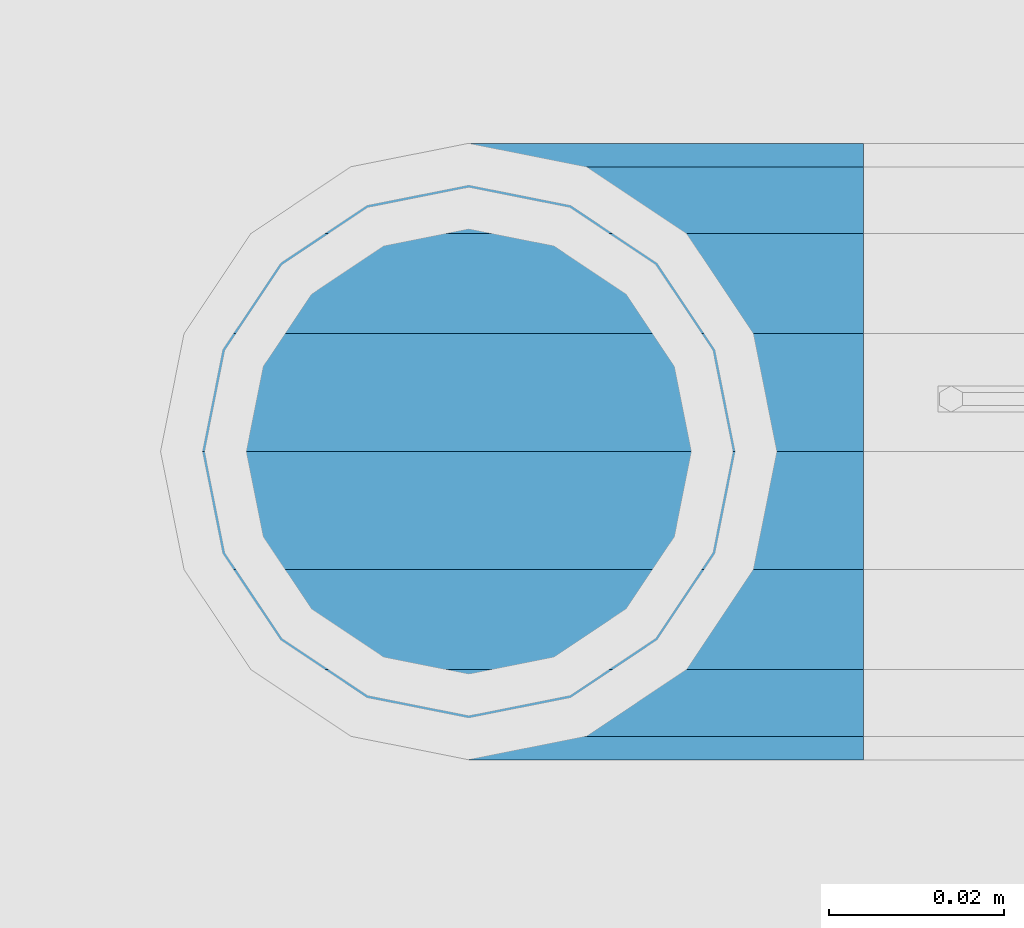
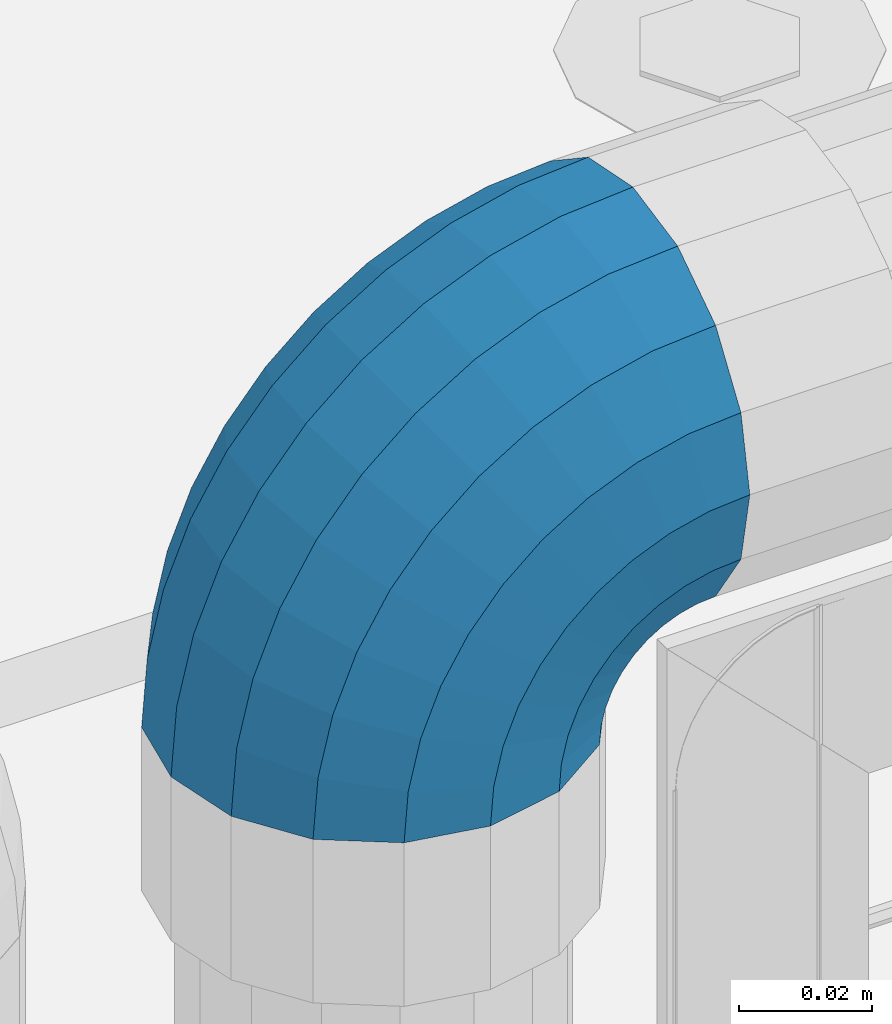
# One storey, part 137 of 208: 1 member.
"""IFC2X3 building model written with IfcOpenShell, lengths in millimetres."""

from ifc_helpers import new_model, si_unit, frame, origin_with_axes, place, context, subcontext, project, spatial, faceted_brep, material, type_object, element, save


model = new_model("IFC2X3")

# Units and contexts
model_context = context("Model", 3, precision=1e-05, world=origin_with_axes())
body_context = subcontext(model_context, "Body", "Model", "MODEL_VIEW")
ifc_project = project(units=[si_unit("LENGTHUNIT", "METRE", prefix="MILLI"), si_unit("AREAUNIT", "SQUARE_METRE"), si_unit("VOLUMEUNIT", "CUBIC_METRE"), si_unit("MASSUNIT", "GRAM", prefix="KILO"), si_unit("TIMEUNIT", "SECOND"), si_unit("PLANEANGLEUNIT", "RADIAN"), si_unit("SOLIDANGLEUNIT", "STERADIAN"), si_unit("THERMODYNAMICTEMPERATUREUNIT", "DEGREE_CELSIUS"), si_unit("LUMINOUSINTENSITYUNIT", "LUMEN")], contexts=[model_context])

# Site, building, storey
site_placement = place(None, origin_with_axes())
site = spatial("IfcSite", under=ifc_project, at=site_placement, CompositionType="ELEMENT")
building_placement = place(site_placement, origin_with_axes())
building = spatial("IfcBuilding", under=site, at=building_placement, Name="Standard", CompositionType="ELEMENT")
storey_placement = place(building_placement, origin_with_axes())
storey = spatial("IfcBuildingStorey", under=building, at=storey_placement, Name="Undefined", CompositionType="ELEMENT", Elevation=0.0)

# Member
ifc_material = material(Name="Misc_Undefined")
member_type = type_object("IfcMemberType", PredefinedType="NOTDEFINED")
member_placement = place(storey_placement, frame((-27328.39, 4664.5, 924.849999999999), z_axis=(-0.707106781186548, 0.0, 0.707106781186548), x_axis=(0.707106781186539, -1.49999999888231e-07, 0.70710678118654)))
element("IfcMember", 1, at=member_placement, inside=storey, type_object=member_type, material=ifc_material, context=body_context, shape_type="Brep", body=[
    faceted_brep([(0.0, -35.1499999999996, 0.0), (9.51152146007371, -32.4743655677721, -9.51152146006643), (13.2759578763435, -32.4743655677721, -6.29638902527222), (5.3694688002397, -35.1499999999996, 4.58595959348168), (17.5750000000044, -24.8548033587067, -17.5749999999971), (19.9787556631163, -24.8548033587067, -15.5219987155615), (22.9628441077075, -13.4513226476329, -22.9628441076966), (24.4574219585302, -13.4513226476329, -21.6863540323902), (24.854803358714, 0.0, -24.8548033587031), (26.0301204183197, 0.0, -23.8509877588003), (22.9628441077075, 13.4513226476329, -22.9628441076966), (24.4574219585302, 13.4513226476329, -21.6863540323902), (17.5750000000044, 24.8548033587067, -17.5749999999971), (19.9787556631163, 24.8548033587067, -15.5219987155615), (9.51152146007371, 32.4743655677721, -9.51152146006643), (13.2759578763435, 32.4743655677721, -6.29638902527222), (0.0, 35.1499999999996, 0.0), (5.3694688002397, 35.1499999999996, 4.58595959348168), (-9.51152146006643, 32.4743655677721, 9.51152146007371), (-2.53702027587133, 32.4743655677721, 15.4683082122356), (-17.5749999999935, 24.8548033587067, 17.5750000000044), (-9.23981806264055, 24.8548033587067, 24.6939179025248), (-22.9628441076966, 13.4513226476329, 22.9628441077039), (-13.7184843580508, 13.4513226476329, 30.8582732193536), (-24.8548033587031, 0.0, 24.854803358714), (-15.2911828178439, 0.0, 33.02290694576), (-22.9628441076966, -13.4513226476329, 22.9628441077039), (-13.7184843580508, -13.4513226476329, 30.8582732193536), (-17.5749999999935, -24.8548033587067, 17.5750000000044), (-9.23981806264055, -24.8548033587067, 24.6939179025248), (-9.51152146006643, -32.4743655677721, 9.51152146007371), (-2.53702027587133, -32.4743655677721, 15.4683082122356), (0.0, -30.3500000000004, 0.0), (-8.21265081971433, -28.0397438117179, 8.21265081972524), (-1.45732902223244, -28.0397438117179, 13.9822406910389), (5.3694688002397, -30.3500000000004, 4.58595959348168), (-15.1749999999956, -21.4606908090118, 15.1750000000029), (-7.24480876130838, -21.4606908090118, 21.9480231689995), (-19.8270929919963, -11.6144421722802, 19.8270929920036), (-11.1118790903529, -11.6144421722802, 27.2705888550809), (-21.4606908090063, 0.0, 21.4606908090136), (-12.46981360684, 0.0, 29.139625372758), (-19.8270929919963, 11.6144421722802, 19.8270929920036), (-11.1118790903529, 11.6144421722802, 27.2705888550809), (-15.1749999999956, 21.4606908090118, 15.1750000000029), (-7.24480876130838, 21.4606908090118, 21.9480231689995), (-8.21265081971433, 28.0397438117179, 8.21265081972524), (-1.45732902223244, 28.0397438117179, 13.9822406910389), (0.0, 30.3500000000004, 0.0), (5.3694688002397, 30.3500000000004, 4.58595959348168), (8.21265081972524, 28.0397438117179, -8.21265081971433), (12.1962666227082, 28.0397438117179, -4.81032150407918), (15.1750000000029, 21.4606908090118, -15.1749999999956), (17.9837463617841, 21.4606908090118, -12.7761039820325), (19.8270929920036, 11.6144421722802, -19.8270929919963), (21.850816690825, 11.6144421722802, -18.0986696681175), (21.4606908090136, 0.0, -21.4606908090063), (23.2087512073158, 0.0, -19.9677061857983), (19.8270929920036, -11.6144421722802, -19.8270929919963), (21.850816690825, -11.6144421722802, -18.0986696681175), (15.1750000000029, -21.4606908090118, -15.1749999999956), (17.9837463617841, -21.4606908090118, -12.7761039820325), (8.21265081972524, -28.0397438117179, -8.21265081971433), (12.1962666227082, -28.0397438117179, -4.81032150407918), (17.4970053560755, -32.4743655677721, -3.70972780291777), (11.3902326651187, -35.1499999999996, 8.27548843508339), (22.6740772628655, -24.8548033587067, -13.870303514941), (26.1332861179544, -13.4513226476329, -20.6593831546779), (27.3479987309656, 0.0, -23.0433908901359), (26.1332861179544, 13.4513226476329, -20.6593831546779), (22.6740772628655, 24.8548033587067, -13.870303514941), (17.4970053560755, 32.4743655677721, -3.70972780291777), (11.3902326651187, 35.1499999999996, 8.27548843508339), (5.28345997416181, 32.4743655677721, 20.2607046730918), (0.106388067368243, 24.8548033587067, 30.4212803851115), (-3.3528207877207, 13.4513226476329, 37.2103600248483), (-4.56753340072828, 0.0, 39.59436776031), (-3.3528207877207, -13.4513226476329, 37.2103600248483), (0.106388067368243, -24.8548033587067, 30.4212803851115), (5.28345997416181, -32.4743655677721, 20.2607046730918), (6.11738625912767, -28.0397438117179, 18.6240321853948), (11.3902326651187, -30.3500000000004, 8.27548843508339), (1.64728291998108, -21.4606908090118, 27.3971039595053), (-1.33954464053022, -11.6144421722802, 33.2590831078996), (-2.38837900197541, 0.0, 35.3175364441995), (-1.33954464053022, 11.6144421722802, 33.2590831078996), (1.64728291998108, 21.4606908090118, 27.3971039595053), (6.11738625912767, 28.0397438117179, 18.6240321853948), (11.3902326651187, 30.3500000000004, 8.27548843508339), (16.663079071106, 28.0397438117179, -2.07305531522434), (21.1331824102563, 21.4606908090118, -10.8461270893349), (24.1200099707712, 11.6144421722802, -16.7081062377256), (25.1688443322128, 0.0, -18.7665595740327), (24.1200099707712, -11.6144421722802, -16.7081062377256), (21.1331824102563, -21.4606908090118, -10.8461270893349), (16.663079071106, -28.0397438117179, -2.07305531522434), (22.0707277014626, -32.4743655677721, -1.81522997692809), (17.9140404065256, -35.1499999999996, 10.9777380798914), (25.5945970362154, -24.8548033587067, -12.6605846156417), (27.9491712485142, -13.4513226476329, -19.9072189058897), (28.7759877588032, 0.0, -22.4518984678834), (27.9491712485142, 13.4513226476329, -19.9072189058897), (25.5945970362154, 24.8548033587067, -12.6605846156417), (22.0707277014626, 32.4743655677721, -1.81522997692809), (17.9140404065256, 35.1499999999996, 10.9777380798914), (13.7573531115886, 32.4743655677721, 23.7707061367109), (10.2334837768358, 24.8548033587067, 34.6160607754246), (7.87890956454066, 13.4513226476329, 41.8626950656726), (7.05209305424796, 0.0, 44.4073746276663), (7.87890956454066, -13.4513226476329, 41.8626950656726), (10.2334837768358, -24.8548033587067, 34.6160607754246), (13.7573531115886, -32.4743655677721, 23.7707061367109), (14.3249803951076, -28.0397438117179, 22.023728990971), (17.9140404065256, -30.3500000000004, 10.9777380798914), (11.2823222355146, -21.4606908090118, 31.3880679180002), (9.2492830507872, -11.6144421722802, 37.6451191472734), (8.53537462724489, 0.0, 39.8423033494473), (9.2492830507872, 11.6144421722802, 37.6451191472734), (11.2823222355146, 21.4606908090118, 31.3880679180002), (14.3249803951076, 28.0397438117179, 22.023728990971), (17.9140404065256, 30.3500000000004, 10.9777380798914), (21.5031004179436, 28.0397438117179, -0.0682528311917849), (24.5457585775366, 21.4606908090118, -9.43259175821368), (26.5787977622676, 11.6144421722802, -15.6896429874905), (27.2927061858063, 0.0, -17.8868271896645), (26.5787977622676, -11.6144421722802, -15.6896429874905), (24.5457585775366, -21.4606908090118, -9.43259175821368), (21.5031004179436, -28.0397438117179, -0.0682528311917849), (26.8845046890528, -32.4743655677721, -0.659544371261291), (24.7802542265854, -35.1499999999996, 12.6261701733893), (28.6684020936882, -24.8548033587067, -11.9226293117899), (29.860364231703, -13.4513226476329, -19.4483820661189), (30.2789256727519, 0.0, -22.0910749985305), (29.860364231703, 13.4513226476329, -19.4483820661189), (28.6684020936882, 24.8548033587067, -11.9226293117899), (26.8845046890528, 32.4743655677721, -0.659544371261291), (24.7802542265854, 35.1499999999996, 12.6261701733893), (22.6760037641179, 32.4743655677721, 25.9118847180434), (20.8921063594898, 24.8548033587067, 37.1749696585721), (19.7001442214714, 13.4513226476329, 44.7007224129011), (19.2815827804225, 0.0, 47.343415345309), (19.7001442214714, -13.4513226476329, 44.7007224129011), (20.8921063594898, -24.8548033587067, 37.1749696585721), (22.6760037641179, -32.4743655677721, 25.9118847180434), (22.9633551786246, -28.0397438117179, 24.0976192894668), (24.7802542265854, -30.3500000000004, 12.6261701733893), (21.4230625404853, -21.4606908090118, 33.8226442665691), (20.3938719035395, -11.6144421722802, 40.3206982094998), (20.0324682126193, 0.0, 42.6025113104552), (20.3938719035395, 11.6144421722802, 40.3206982094998), (21.4230625404853, 21.4606908090118, 33.8226442665691), (22.9633551786246, 28.0397438117179, 24.0976192894668), (24.7802542265854, 30.3500000000004, 12.6261701733893), (26.5971532745498, 28.0397438117179, 1.15472105731169), (28.1374459126891, 21.4606908090118, -8.5703039197906), (29.1666365496385, 11.6144421722802, -15.0683578627177), (29.5280402405588, 0.0, -17.350170963673), (29.1666365496385, -11.6144421722802, -15.0683578627177), (28.1374459126891, -21.4606908090118, -8.5703039197906), (26.5971532745498, -28.0397438117179, 1.15472105731169), (31.8198051533982, -32.4743655677721, -0.271127801024704), (31.8198051533982, -35.1499999999996, 13.1801948466091), (31.8198051533982, -24.8548033587067, -11.6746085120976), (31.8198051533982, -13.4513226476329, -19.2941707211648), (31.8198051533982, 0.0, -21.9698051533924), (31.8198051533982, 13.4513226476329, -19.2941707211648), (31.8198051533982, 24.8548033587067, -11.6746085120976), (31.8198051533982, 32.4743655677721, -0.271127801024704), (31.8198051533982, 35.1499999999996, 13.1801948466091), (31.8198051533982, 32.4743655677721, 26.6315174942429), (31.8198051533982, 24.8548033587067, 38.0349982053158), (31.8198051533946, 13.4513226476329, 45.654560414383), (31.8198051534018, 0.0, 48.3301948466105), (31.8198051533946, -13.4513226476329, 45.654560414383), (31.8198051533982, -24.8548033587067, 38.0349982053158), (31.8198051533982, -32.4743655677721, 26.6315174942429), (31.8198051533982, -28.0397438117179, 24.7946370188874), (31.8198051533982, -30.3500000000004, 13.1801948466091), (31.8198051533982, -21.4606908090118, 34.6408856556227), (31.8198051533982, -11.6144421722802, 41.219938658327), (31.8198051533982, 0.0, 43.5301948466113), (31.8198051533982, 11.6144421722802, 41.219938658327), (31.8198051533982, 21.4606908090118, 34.6408856556227), (31.8198051533982, 28.0397438117179, 24.7946370188874), (31.8198051533982, 30.3500000000004, 13.1801948466091), (31.8198051533946, 28.0397438117179, 1.56575267433072), (31.8198051533982, 21.4606908090118, -8.28049596240453), (31.8198051533982, 11.6144421722802, -14.8595489651088), (31.8198051533982, 0.0, -17.1698051533895), (31.8198051533982, -11.6144421722802, -14.8595489651088), (31.8198051533982, -21.4606908090118, -8.28049596240453), (31.8198051533946, -28.0397438117179, 1.56575267433072), (36.7551056177435, -32.4743655677721, -0.659544371261291), (38.859356080211, -35.1499999999996, 12.6261701733929), (34.9712082131082, -24.8548033587067, -11.9226293117899), (33.7792460750898, -13.4513226476329, -19.4483820661189), (33.3606846340444, 0.0, -22.0910749985269), (33.7792460750898, 13.4513226476329, -19.4483820661189), (34.9712082131082, 24.8548033587067, -11.9226293117899), (36.7551056177435, 32.4743655677721, -0.659544371261291), (38.859356080211, 35.1499999999996, 12.6261701733929), (40.9636065426712, 32.4743655677721, 25.9118847180434), (42.7475039473065, 24.8548033587067, 37.1749696585684), (43.939466085325, 13.4513226476329, 44.7007224129047), (44.3580275263703, 0.0, 47.343415345309), (43.939466085325, -13.4513226476329, 44.7007224129047), (42.7475039473065, -24.8548033587067, 37.1749696585684), (40.9636065426712, -32.4743655677721, 25.9118847180434), (40.6762551281718, -28.0397438117179, 24.0976192894668), (38.859356080211, -30.3500000000004, 12.6261701733929), (42.2165477663111, -21.4606908090118, 33.8226442665691), (43.2457384032568, -11.6144421722802, 40.3206982094998), (43.6071420941771, 0.0, 42.6025113104515), (43.2457384032568, 11.6144421722802, 40.3206982094998), (42.2165477663111, 21.4606908090118, 33.8226442665691), (40.6762551281718, 28.0397438117179, 24.0976192894668), (38.859356080211, 30.3500000000004, 12.6261701733929), (37.0424570322466, 28.0397438117179, 1.15472105731169), (35.5021643941072, 21.4606908090118, -8.5703039197906), (34.4729737571579, 11.6144421722802, -15.0683578627177), (34.1115700662376, 0.0, -17.350170963673), (34.4729737571579, -11.6144421722802, -15.0683578627177), (35.5021643941072, -21.4606908090118, -8.5703039197906), (37.0424570322466, -28.0397438117179, 1.15472105731169), (41.5688826053338, -32.4743655677721, -1.81522997692809), (45.7255699002708, -35.1499999999996, 10.9777380798914), (38.045013270581, -24.8548033587067, -12.6605846156417), (35.6904390582822, -13.4513226476329, -19.9072189058897), (34.8636225479895, 0.0, -22.4518984678834), (35.6904390582822, 13.4513226476329, -19.9072189058897), (38.045013270581, 24.8548033587067, -12.6605846156417), (41.5688826053338, 32.4743655677721, -1.81522997692809), (45.7255699002708, 35.1499999999996, 10.9777380798914), (49.8822571952114, 32.4743655677721, 23.7707061367109), (53.4061265299606, 24.8548033587067, 34.6160607754246), (55.7607007422557, 13.4513226476329, 41.8626950656726), (56.5875172525484, 0.0, 44.4073746276699), (55.7607007422557, -13.4513226476329, 41.8626950656726), (53.4061265299606, -24.8548033587067, 34.6160607754246), (49.8822571952114, -32.4743655677721, 23.7707061367109), (49.3146299116925, -28.0397438117179, 22.0237289909746), (45.7255699002708, -30.3500000000004, 10.9777380798914), (52.3572880712818, -21.4606908090118, 31.3880679179965), (54.3903272560092, -11.6144421722802, 37.6451191472697), (55.1042356795515, 0.0, 39.8423033494473), (54.3903272560092, 11.6144421722802, 37.6451191472697), (52.3572880712818, 21.4606908090118, 31.3880679179965), (49.3146299116925, 28.0397438117179, 22.0237289909746), (45.7255699002708, 30.3500000000004, 10.9777380798914), (42.1365098888527, 28.0397438117179, -0.0682528311917849), (39.0938517292598, 21.4606908090118, -9.43259175821368), (37.0608125445287, 11.6144421722802, -15.6896429874905), (36.3469041209937, 0.0, -17.8868271896645), (37.0608125445287, -11.6144421722802, -15.6896429874905), (39.0938517292598, -21.4606908090118, -9.43259175821368), (42.1365098888527, -28.0397438117179, -0.0682528311917849), (46.1426049507245, -32.4743655677721, -3.70972780291777), (52.2493776416777, -35.1499999999996, 8.27548843508339), (40.9655330439309, -24.8548033587067, -13.870303514941), (37.506324188842, -13.4513226476329, -20.6593831546743), (36.2916115758308, 0.0, -23.0433908901359), (37.506324188842, 13.4513226476329, -20.6593831546743), (40.9655330439309, 24.8548033587067, -13.870303514941), (46.1426049507245, 32.4743655677721, -3.70972780291777), (52.2493776416777, 35.1499999999996, 8.27548843508339), (58.3561503326309, 32.4743655677721, 20.2607046730918), (63.5332222394245, 24.8548033587067, 30.4212803851151), (66.9924310945171, 13.4513226476329, 37.2103600248483), (68.207143707521, 0.0, 39.5943677603063), (66.9924310945171, -13.4513226476329, 37.2103600248483), (63.5332222394245, -24.8548033587067, 30.4212803851151), (58.3561503326309, -32.4743655677721, 20.2607046730918), (57.5222240476687, -28.0397438117179, 18.6240321853984), (52.2493776416777, -30.3500000000004, 8.27548843508339), (61.9923273868153, -21.4606908090118, 27.3971039595053), (64.9791549473266, -11.6144421722802, 33.259083107896), (66.0279893087718, 0.0, 35.3175364442068), (64.9791549473266, 11.6144421722802, 33.259083107896), (61.9923273868153, 21.4606908090118, 27.3971039595053), (57.5222240476687, 28.0397438117179, 18.6240321853984), (52.2493776416777, 30.3500000000004, 8.27548843508339), (46.9765312356867, 28.0397438117179, -2.0730553152207), (42.5064278965401, 21.4606908090118, -10.8461270893349), (39.5196003360288, 11.6144421722802, -16.7081062377256), (38.4707659745836, 0.0, -18.7665595740327), (39.5196003360288, -11.6144421722802, -16.7081062377256), (42.5064278965401, -21.4606908090118, -10.8461270893349), (46.9765312356867, -28.0397438117179, -2.0730553152207), (50.3636524304529, -32.4743655677721, -6.29638902527222), (58.2701415065603, -35.1499999999996, 4.58595959348168), (43.6608546436801, -24.8548033587067, -15.5219987155615), (39.1821883482698, -13.4513226476329, -21.6863540323902), (37.6094898884767, 0.0, -23.8509877587967), (39.1821883482698, 13.4513226476329, -21.6863540323902), (43.6608546436801, 24.8548033587067, -15.5219987155615), (50.3636524304529, 32.4743655677721, -6.29638902527222), (58.2701415065603, 35.1499999999996, 4.58595959348168), (66.1766305826677, 32.4743655677721, 15.4683082122392), (72.8794283694369, 24.8548033587067, 24.6939179025212), (77.3580946648508, 13.4513226476329, 30.8582732193536), (78.9307931246403, 0.0, 33.02290694576), (77.3580946648508, -13.4513226476329, 30.8582732193536), (72.8794283694369, -24.8548033587067, 24.6939179025212), (66.1766305826677, -32.4743655677721, 15.4683082122392), (65.0969393290288, -28.0397438117179, 13.9822406910425), (58.2701415065603, -30.3500000000004, 4.58595959348168), (70.8844190681048, -21.4606908090118, 21.9480231689995), (74.7514893971456, -11.6144421722802, 27.2705888550845), (76.1094239136364, 0.0, 29.1396253727617), (74.7514893971456, 11.6144421722802, 27.2705888550845), (70.8844190681048, 21.4606908090118, 21.9480231689995), (65.0969393290288, 28.0397438117179, 13.9822406910425), (58.2701415065603, 30.3500000000004, 4.58595959348168), (51.4433436840882, 28.0397438117179, -4.81032150407918), (45.6558639450122, 21.4606908090118, -12.7761039820361), (41.7887936159714, 11.6144421722802, -18.0986696681175), (40.4308590994842, 0.0, -19.9677061857983), (41.7887936159714, -11.6144421722802, -18.0986696681175), (45.6558639450122, -21.4606908090118, -12.7761039820361), (51.4433436840882, -28.0397438117179, -4.81032150407918), (54.1280888467227, -32.4743655677721, -9.51152146006643), (63.6396103067927, -35.1499999999996, 3.63797880709171e-12), (46.064610306792, -24.8548033587067, -17.5749999999971), (40.6767661990889, -13.4513226476329, -22.9628441077002), (38.784806948086, 0.0, -24.8548033587031), (40.6767661990889, 13.4513226476329, -22.9628441077002), (46.064610306792, 24.8548033587067, -17.5749999999971), (54.1280888467227, 32.4743655677721, -9.51152146006643), (63.6396103067927, 35.1499999999996, 3.63797880709171e-12), (73.1511317668628, 32.4743655677721, 9.51152146007371), (81.2146103067935, 24.8548033587067, 17.5750000000044), (86.602454414493, 13.4513226476329, 22.9628441077075), (88.4944136654995, 0.0, 24.8548033587103), (86.602454414493, -13.4513226476329, 22.9628441077075), (81.2146103067935, -24.8548033587067, 17.5750000000044), (73.1511317668628, -32.4743655677721, 9.51152146007371), (71.8522611265107, -28.0397438117179, 8.2126508197216), (63.6396103067927, -30.3500000000004, 3.63797880709171e-12), (78.814610306792, -21.4606908090118, 15.1750000000029), (83.4667032987927, -11.6144421722802, 19.8270929920036), (85.1003011158027, 0.0, 21.4606908090136), (83.4667032987927, 11.6144421722802, 19.8270929920036), (78.814610306792, 21.4606908090118, 15.1750000000029), (71.8522611265107, 28.0397438117179, 8.2126508197216), (63.6396103067927, 30.3500000000004, 3.63797880709171e-12), (55.4269594870748, 28.0397438117179, -8.21265081971433), (48.4646103067935, 21.4606908090118, -15.1749999999956), (43.8125173147928, 11.6144421722802, -19.8270929919963), (42.1789194977791, 0.0, -21.4606908090063), (43.8125173147928, -11.6144421722802, -19.8270929919963), (48.4646103067935, -21.4606908090118, -15.1749999999956), (55.4269594870748, -28.0397438117179, -8.21265081971433)], [[[0, 1, 2, 3]], [[1, 4, 5, 2]], [[4, 6, 7, 5]], [[6, 8, 9, 7]], [[8, 10, 11, 9]], [[10, 12, 13, 11]], [[12, 14, 15, 13]], [[14, 16, 17, 15]], [[16, 18, 19, 17]], [[18, 20, 21, 19]], [[20, 22, 23, 21]], [[22, 24, 25, 23]], [[24, 26, 27, 25]], [[26, 28, 29, 27]], [[28, 30, 31, 29]], [[30, 0, 3, 31]], [[32, 33, 34, 35]], [[33, 36, 37, 34]], [[36, 38, 39, 37]], [[38, 40, 41, 39]], [[40, 42, 43, 41]], [[42, 44, 45, 43]], [[44, 46, 47, 45]], [[46, 48, 49, 47]], [[48, 50, 51, 49]], [[50, 52, 53, 51]], [[52, 54, 55, 53]], [[54, 56, 57, 55]], [[56, 58, 59, 57]], [[58, 60, 61, 59]], [[60, 62, 63, 61]], [[62, 32, 35, 63]], [[30, 28, 26, 24, 22, 20, 18, 16, 14, 12, 10, 8, 6, 4, 1, 0], [62, 60, 58, 56, 54, 52, 50, 48, 46, 44, 42, 40, 38, 36, 33, 32]], [[3, 2, 64, 65]], [[2, 5, 66, 64]], [[5, 7, 67, 66]], [[7, 9, 68, 67]], [[9, 11, 69, 68]], [[11, 13, 70, 69]], [[13, 15, 71, 70]], [[15, 17, 72, 71]], [[17, 19, 73, 72]], [[19, 21, 74, 73]], [[21, 23, 75, 74]], [[23, 25, 76, 75]], [[25, 27, 77, 76]], [[27, 29, 78, 77]], [[29, 31, 79, 78]], [[31, 3, 65, 79]], [[35, 34, 80, 81]], [[34, 37, 82, 80]], [[37, 39, 83, 82]], [[39, 41, 84, 83]], [[41, 43, 85, 84]], [[43, 45, 86, 85]], [[45, 47, 87, 86]], [[47, 49, 88, 87]], [[49, 51, 89, 88]], [[51, 53, 90, 89]], [[53, 55, 91, 90]], [[55, 57, 92, 91]], [[57, 59, 93, 92]], [[59, 61, 94, 93]], [[61, 63, 95, 94]], [[63, 35, 81, 95]], [[65, 64, 96, 97]], [[64, 66, 98, 96]], [[66, 67, 99, 98]], [[67, 68, 100, 99]], [[68, 69, 101, 100]], [[69, 70, 102, 101]], [[70, 71, 103, 102]], [[71, 72, 104, 103]], [[72, 73, 105, 104]], [[73, 74, 106, 105]], [[74, 75, 107, 106]], [[75, 76, 108, 107]], [[76, 77, 109, 108]], [[77, 78, 110, 109]], [[78, 79, 111, 110]], [[79, 65, 97, 111]], [[81, 80, 112, 113]], [[80, 82, 114, 112]], [[82, 83, 115, 114]], [[83, 84, 116, 115]], [[84, 85, 117, 116]], [[85, 86, 118, 117]], [[86, 87, 119, 118]], [[87, 88, 120, 119]], [[88, 89, 121, 120]], [[89, 90, 122, 121]], [[90, 91, 123, 122]], [[91, 92, 124, 123]], [[92, 93, 125, 124]], [[93, 94, 126, 125]], [[94, 95, 127, 126]], [[95, 81, 113, 127]], [[97, 96, 128, 129]], [[96, 98, 130, 128]], [[98, 99, 131, 130]], [[99, 100, 132, 131]], [[100, 101, 133, 132]], [[101, 102, 134, 133]], [[102, 103, 135, 134]], [[103, 104, 136, 135]], [[104, 105, 137, 136]], [[105, 106, 138, 137]], [[106, 107, 139, 138]], [[107, 108, 140, 139]], [[108, 109, 141, 140]], [[109, 110, 142, 141]], [[110, 111, 143, 142]], [[111, 97, 129, 143]], [[113, 112, 144, 145]], [[112, 114, 146, 144]], [[114, 115, 147, 146]], [[115, 116, 148, 147]], [[116, 117, 149, 148]], [[117, 118, 150, 149]], [[118, 119, 151, 150]], [[119, 120, 152, 151]], [[120, 121, 153, 152]], [[121, 122, 154, 153]], [[122, 123, 155, 154]], [[123, 124, 156, 155]], [[124, 125, 157, 156]], [[125, 126, 158, 157]], [[126, 127, 159, 158]], [[127, 113, 145, 159]], [[129, 128, 160, 161]], [[128, 130, 162, 160]], [[130, 131, 163, 162]], [[131, 132, 164, 163]], [[132, 133, 165, 164]], [[133, 134, 166, 165]], [[134, 135, 167, 166]], [[135, 136, 168, 167]], [[136, 137, 169, 168]], [[137, 138, 170, 169]], [[138, 139, 171, 170]], [[139, 140, 172, 171]], [[140, 141, 173, 172]], [[141, 142, 174, 173]], [[142, 143, 175, 174]], [[143, 129, 161, 175]], [[145, 144, 176, 177]], [[144, 146, 178, 176]], [[146, 147, 179, 178]], [[147, 148, 180, 179]], [[148, 149, 181, 180]], [[149, 150, 182, 181]], [[150, 151, 183, 182]], [[151, 152, 184, 183]], [[152, 153, 185, 184]], [[153, 154, 186, 185]], [[154, 155, 187, 186]], [[155, 156, 188, 187]], [[156, 157, 189, 188]], [[157, 158, 190, 189]], [[158, 159, 191, 190]], [[159, 145, 177, 191]], [[161, 160, 192, 193]], [[160, 162, 194, 192]], [[162, 163, 195, 194]], [[163, 164, 196, 195]], [[164, 165, 197, 196]], [[165, 166, 198, 197]], [[166, 167, 199, 198]], [[167, 168, 200, 199]], [[168, 169, 201, 200]], [[169, 170, 202, 201]], [[170, 171, 203, 202]], [[171, 172, 204, 203]], [[172, 173, 205, 204]], [[173, 174, 206, 205]], [[174, 175, 207, 206]], [[175, 161, 193, 207]], [[177, 176, 208, 209]], [[176, 178, 210, 208]], [[178, 179, 211, 210]], [[179, 180, 212, 211]], [[180, 181, 213, 212]], [[181, 182, 214, 213]], [[182, 183, 215, 214]], [[183, 184, 216, 215]], [[184, 185, 217, 216]], [[185, 186, 218, 217]], [[186, 187, 219, 218]], [[187, 188, 220, 219]], [[188, 189, 221, 220]], [[189, 190, 222, 221]], [[190, 191, 223, 222]], [[191, 177, 209, 223]], [[193, 192, 224, 225]], [[192, 194, 226, 224]], [[194, 195, 227, 226]], [[195, 196, 228, 227]], [[196, 197, 229, 228]], [[197, 198, 230, 229]], [[198, 199, 231, 230]], [[199, 200, 232, 231]], [[200, 201, 233, 232]], [[201, 202, 234, 233]], [[202, 203, 235, 234]], [[203, 204, 236, 235]], [[204, 205, 237, 236]], [[205, 206, 238, 237]], [[206, 207, 239, 238]], [[207, 193, 225, 239]], [[209, 208, 240, 241]], [[208, 210, 242, 240]], [[210, 211, 243, 242]], [[211, 212, 244, 243]], [[212, 213, 245, 244]], [[213, 214, 246, 245]], [[214, 215, 247, 246]], [[215, 216, 248, 247]], [[216, 217, 249, 248]], [[217, 218, 250, 249]], [[218, 219, 251, 250]], [[219, 220, 252, 251]], [[220, 221, 253, 252]], [[221, 222, 254, 253]], [[222, 223, 255, 254]], [[223, 209, 241, 255]], [[225, 224, 256, 257]], [[224, 226, 258, 256]], [[226, 227, 259, 258]], [[227, 228, 260, 259]], [[228, 229, 261, 260]], [[229, 230, 262, 261]], [[230, 231, 263, 262]], [[231, 232, 264, 263]], [[232, 233, 265, 264]], [[233, 234, 266, 265]], [[234, 235, 267, 266]], [[235, 236, 268, 267]], [[236, 237, 269, 268]], [[237, 238, 270, 269]], [[238, 239, 271, 270]], [[239, 225, 257, 271]], [[241, 240, 272, 273]], [[240, 242, 274, 272]], [[242, 243, 275, 274]], [[243, 244, 276, 275]], [[244, 245, 277, 276]], [[245, 246, 278, 277]], [[246, 247, 279, 278]], [[247, 248, 280, 279]], [[248, 249, 281, 280]], [[249, 250, 282, 281]], [[250, 251, 283, 282]], [[251, 252, 284, 283]], [[252, 253, 285, 284]], [[253, 254, 286, 285]], [[254, 255, 287, 286]], [[255, 241, 273, 287]], [[257, 256, 288, 289]], [[256, 258, 290, 288]], [[258, 259, 291, 290]], [[259, 260, 292, 291]], [[260, 261, 293, 292]], [[261, 262, 294, 293]], [[262, 263, 295, 294]], [[263, 264, 296, 295]], [[264, 265, 297, 296]], [[265, 266, 298, 297]], [[266, 267, 299, 298]], [[267, 268, 300, 299]], [[268, 269, 301, 300]], [[269, 270, 302, 301]], [[270, 271, 303, 302]], [[271, 257, 289, 303]], [[273, 272, 304, 305]], [[272, 274, 306, 304]], [[274, 275, 307, 306]], [[275, 276, 308, 307]], [[276, 277, 309, 308]], [[277, 278, 310, 309]], [[278, 279, 311, 310]], [[279, 280, 312, 311]], [[280, 281, 313, 312]], [[281, 282, 314, 313]], [[282, 283, 315, 314]], [[283, 284, 316, 315]], [[284, 285, 317, 316]], [[285, 286, 318, 317]], [[286, 287, 319, 318]], [[287, 273, 305, 319]], [[289, 288, 320, 321]], [[288, 290, 322, 320]], [[290, 291, 323, 322]], [[291, 292, 324, 323]], [[292, 293, 325, 324]], [[293, 294, 326, 325]], [[294, 295, 327, 326]], [[295, 296, 328, 327]], [[296, 297, 329, 328]], [[297, 298, 330, 329]], [[298, 299, 331, 330]], [[299, 300, 332, 331]], [[300, 301, 333, 332]], [[301, 302, 334, 333]], [[302, 303, 335, 334]], [[303, 289, 321, 335]], [[305, 304, 336, 337]], [[304, 306, 338, 336]], [[306, 307, 339, 338]], [[307, 308, 340, 339]], [[308, 309, 341, 340]], [[309, 310, 342, 341]], [[310, 311, 343, 342]], [[311, 312, 344, 343]], [[312, 313, 345, 344]], [[313, 314, 346, 345]], [[314, 315, 347, 346]], [[315, 316, 348, 347]], [[316, 317, 349, 348]], [[317, 318, 350, 349]], [[318, 319, 351, 350]], [[319, 305, 337, 351]], [[322, 323, 324, 325, 326, 327, 328, 329, 330, 331, 332, 333, 334, 335, 321, 320], [338, 339, 340, 341, 342, 343, 344, 345, 346, 347, 348, 349, 350, 351, 337, 336]]]),
])

save(model, "model.ifc")
